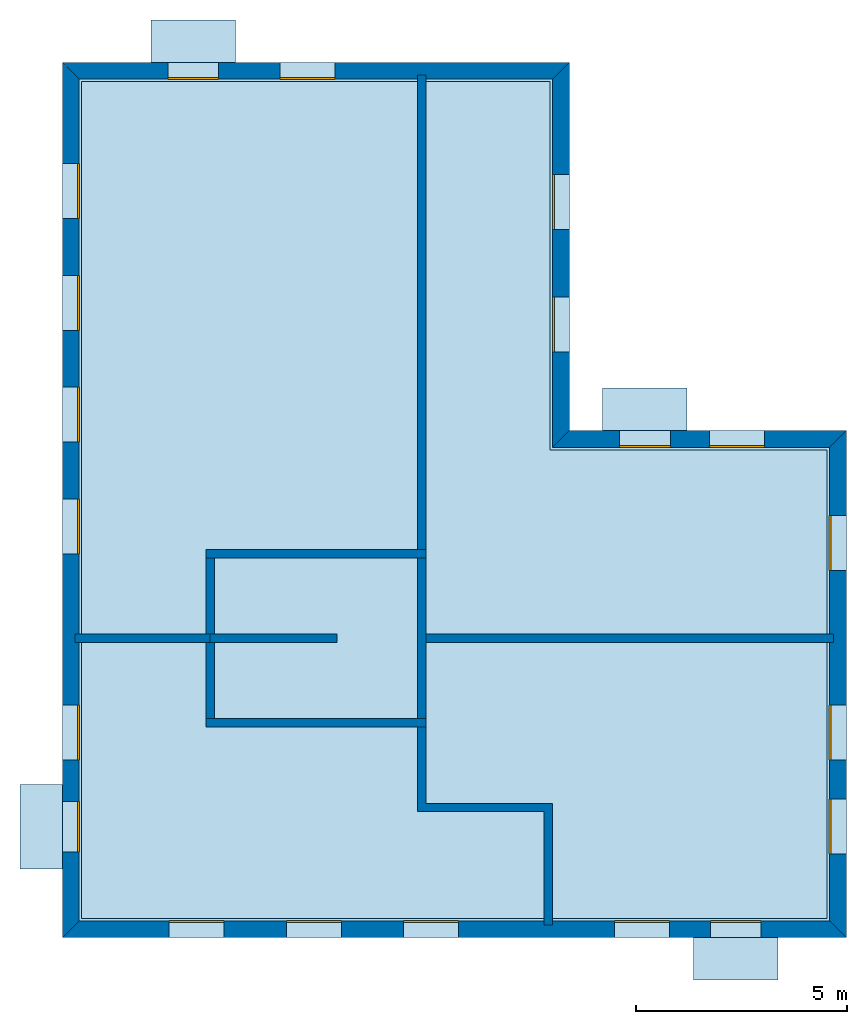
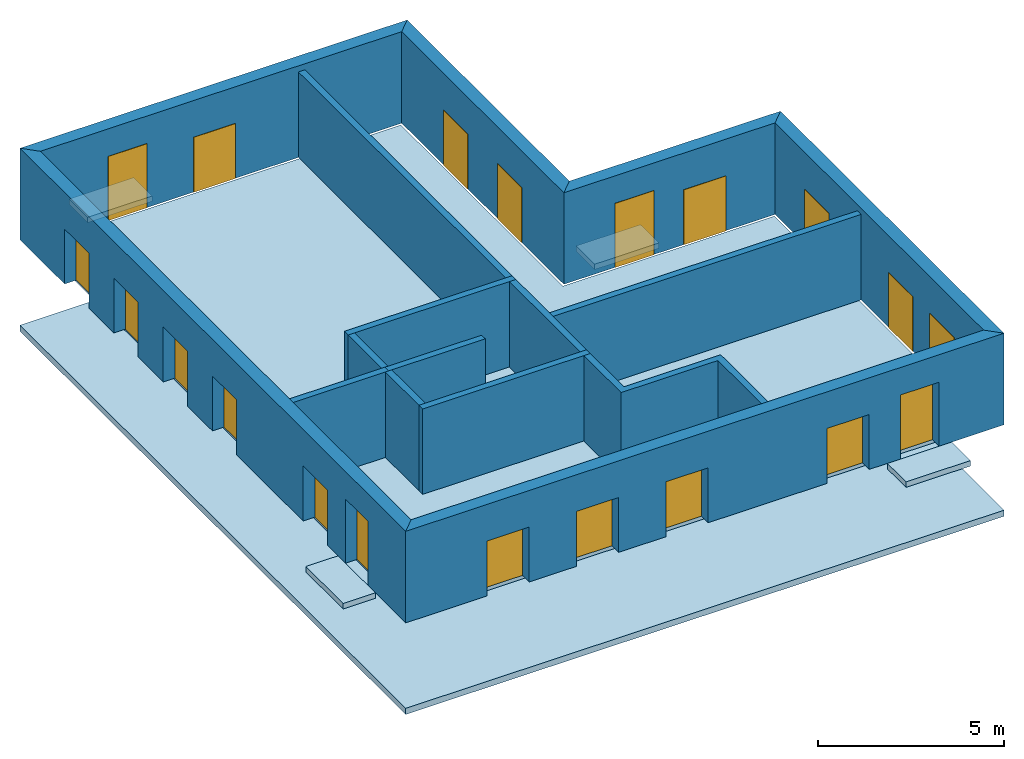
# One storey: 20 windows, 15 walls, 6 slabs, 20 openings.
"""IFC4 building model written with IfcOpenShell, lengths in metres."""

from ifc_helpers import new_model, si_unit, frame, origin_with_axes, place, context, subcontext, project, spatial, polyline, line, indexed_curve, outline, extrude, element, fill, save


model = new_model("IFC4")

# Units and contexts
model_context = context("Model", 3, precision=1e-05, world=origin_with_axes())
body_context = subcontext(model_context, "Body", "Model", "MODEL_VIEW")
ifc_project = project(units=[si_unit("AREAUNIT", "SQUARE_METRE"), si_unit("VOLUMEUNIT", "CUBIC_METRE"), si_unit("LENGTHUNIT", "METRE")], contexts=[model_context])

# Site, building, storey
site = spatial("IfcSite", under=ifc_project)
building = spatial("IfcBuilding", under=site, Name="Building 2")
storey_placement = place(None, frame((0.0, 0.0, 7.0), z_axis=(0.0, 0.0, 1.0), x_axis=(1.0, 0.0, 0.0)))
storey = spatial("IfcBuildingStorey", under=building, at=storey_placement, Name="03 Storey")

# Slabs
slab_1_placement = place(storey_placement, origin_with_axes())
element("IfcSlab", 1, at=slab_1_placement, inside=storey, Name="Slab", context=body_context, shape_type="SweptSolid", body=[
    extrude(outline(indexed_curve([(22.079464, -3.619175), (15.533354, -3.619175), (15.533354, 5.0882), (4.453354, 5.0882), (4.453354, -14.699175), (22.079464, -14.699175)], segments=[line(1, 2), line(2, 3), line(3, 4), line(4, 5), line(5, 6)])), origin_with_axes(), (0.0, 0.0, -1.0), 0.2),
])
slab_2_placement = place(storey_placement, origin_with_axes())
element("IfcSlab", 2, at=slab_2_placement, inside=storey, Name="Balcony", context=body_context, shape_type="SweptSolid", body=[
    extrude(outline(indexed_curve([(6.093354, 5.5482), (6.093354, 6.5482), (8.093354, 6.5482), (8.093354, 5.5482)], segments=[line(1, 2), line(2, 3), line(3, 4)])), origin_with_axes(), (0.0, 0.0, -1.0), 0.18),
])
slab_3_placement = place(storey_placement, origin_with_axes())
element("IfcSlab", 3, at=slab_3_placement, inside=storey, Name="Balcony", context=body_context, shape_type="SweptSolid", body=[
    extrude(outline(indexed_curve([(16.7753906666667, -3.159175), (16.7753906666667, -2.159175), (18.7753906666667, -2.159175), (18.7753906666667, -3.159175)], segments=[line(1, 2), line(2, 3), line(3, 4)])), origin_with_axes(), (0.0, 0.0, -1.0), 0.18),
])
slab_4_placement = place(storey_placement, origin_with_axes())
element("IfcSlab", 4, at=slab_4_placement, inside=storey, Name="Balcony", context=body_context, shape_type="SweptSolid", body=[
    extrude(outline(indexed_curve([(20.924094, -15.159175), (20.924094, -16.159175), (18.924094, -16.159175), (18.924094, -15.159175)], segments=[line(1, 2), line(2, 3), line(3, 4)])), origin_with_axes(), (0.0, 0.0, -1.0), 0.18),
])
slab_5_placement = place(storey_placement, origin_with_axes())
element("IfcSlab", 5, at=slab_5_placement, inside=storey, Name="Balcony", context=body_context, shape_type="SweptSolid", body=[
    extrude(outline(indexed_curve([(3.993354, -13.5322976666667), (2.993354, -13.5322976666667), (2.993354, -11.5322976666667), (3.993354, -11.5322976666667)], segments=[line(1, 2), line(2, 3), line(3, 4)])), origin_with_axes(), (0.0, 0.0, -1.0), 0.18),
])
slab_6_placement = place(storey_placement, frame((22.5394649505615, -3.15917491912842, 0.0), z_axis=(-1.07062027704125e-23, 1.22464679914735e-16, -1.0), x_axis=(-0.999999999999996, -8.74227800037247e-08, 0.0)))
element("IfcSlab", 6, at=slab_6_placement, inside=storey, Name="Slab", context=body_context, shape_type="SweptSolid", body=[
    extrude(outline(polyline([(0.0, 0.0), (6.54611, 0.0), (6.54611, 8.707375), (18.54611, 8.707375), (18.54611, -12.0), (0.0, -12.0), (0.0, 0.0)])), frame((0.0, 0.0, 3.0), z_axis=(0.0, 0.0, 1.0), x_axis=(1.0, 0.0, 0.0)), (0.0, -4.37113882867379e-08, -1.0), 0.2),
])

# Walls
wall_1_placement = place(storey_placement, origin_with_axes())
element("IfcWall", 7, at=wall_1_placement, inside=storey, Name="Wall", context=body_context, shape_type="SweptSolid", body=[
    extrude(outline(indexed_curve([(7.593354, -7.978543), (4.293354, -7.978543), (4.293354, -8.178543), (7.593354, -8.178543)], segments=[line(1, 2), line(2, 3), line(3, 4)])), origin_with_axes(), (0.0, 0.0, 1.0), 2.8),
])
wall_2_placement = place(storey_placement, origin_with_axes())
element("IfcWall", 8, at=wall_2_placement, inside=storey, Name="Wall", context=body_context, shape_type="SweptSolid", body=[
    extrude(outline(indexed_curve([(12.593354, 5.2482), (12.393354, 5.2482), (12.393354, -6.178543), (12.593354, -6.178543)], segments=[line(1, 2), line(2, 3), line(3, 4)])), origin_with_axes(), (0.0, 0.0, 1.0), 2.8),
])
wall_3_placement = place(storey_placement, origin_with_axes())
element("IfcWall", 9, at=wall_3_placement, inside=storey, Name="Wall", context=body_context, shape_type="SweptSolid", body=[
    extrude(outline(indexed_curve([(22.239464, -7.978543), (12.393354, -7.978543), (12.393354, -8.178543), (22.239464, -8.178543)], segments=[line(1, 2), line(2, 3), line(3, 4)])), origin_with_axes(), (0.0, 0.0, 1.0), 2.8),
])
wall_4_placement = place(storey_placement, origin_with_axes())
element("IfcWall", 10, at=wall_4_placement, inside=storey, Name="Wall", context=body_context, shape_type="SweptSolid", body=[
    extrude(outline(indexed_curve([(15.593354, -11.978543), (12.593354, -11.978543), (12.593354, -9.978543), (12.393354, -9.978543), (12.393354, -12.178543), (15.393354, -12.178543), (15.393354, -14.859175), (15.593354, -14.859175)], segments=[line(1, 2), line(2, 3), line(3, 4), line(4, 5), line(5, 6), line(6, 7), line(7, 8)])), origin_with_axes(), (0.0, 0.0, 1.0), 2.8),
])

# Wall, openings, windows
wall_5_placement = place(storey_placement, origin_with_axes())
wall_5 = element("IfcWall", 11, at=wall_5_placement, inside=storey, Name="Facade", context=body_context, shape_type="SweptSolid", body=[
    extrude(outline(indexed_curve([(22.139464, -3.559175), (15.593354, -3.559175), (15.993354, -3.159175), (22.539464, -3.159175)], segments=[line(1, 2), line(2, 3), line(3, 4)])), origin_with_axes(), (0.0, 0.0, 1.0), 3.0),
])
opening_1_placement = place(wall_5_placement, origin_with_axes())
opening_1 = element("IfcOpeningElement", 12, at=opening_1_placement, cuts=wall_5, Name="Opening", context=body_context, shape_type="SweptSolid", body=[
    extrude(outline(indexed_curve([(20.6074273333333, -3.119175), (20.6074273333333, -3.619175), (19.3074273333333, -3.619175), (19.3074273333333, -3.119175)], segments=[line(1, 2), line(2, 3), line(3, 4)])), origin_with_axes(), (0.0, 0.0, 1.0), 1.8),
])
opening_2_placement = place(wall_5_placement, origin_with_axes())
opening_2 = element("IfcOpeningElement", 13, at=opening_2_placement, cuts=wall_5, Name="Opening", context=body_context, shape_type="SweptSolid", body=[
    extrude(outline(indexed_curve([(18.3753906666667, -3.119175), (18.3753906666667, -3.619175), (17.1753906666667, -3.619175), (17.1753906666667, -3.119175)], segments=[line(1, 2), line(2, 3), line(3, 4)])), origin_with_axes(), (0.0, 0.0, 1.0), 2.1),
])
window_1_placement = place(storey_placement, origin_with_axes())
window_1 = element("IfcWindow", 14, at=window_1_placement, inside=storey, Name="Window", PredefinedType="WINDOW", context=body_context, shape_type="SweptSolid", body=[
    extrude(outline(indexed_curve([(20.6074273333333, -3.519175), (20.6074273333333, -3.569175), (19.3074273333333, -3.569175), (19.3074273333333, -3.519175)], segments=[line(1, 2), line(2, 3), line(3, 4)])), origin_with_axes(), (0.0, 0.0, 1.0), 1.8),
])
fill(opening_1, window_1)
window_2_placement = place(storey_placement, origin_with_axes())
window_2 = element("IfcWindow", 15, at=window_2_placement, inside=storey, Name="Window", PredefinedType="WINDOW", context=body_context, shape_type="SweptSolid", body=[
    extrude(outline(indexed_curve([(18.3753906666667, -3.519175), (18.3753906666667, -3.569175), (17.1753906666667, -3.569175), (17.1753906666667, -3.519175)], segments=[line(1, 2), line(2, 3), line(3, 4)])), origin_with_axes(), (0.0, 0.0, 1.0), 2.1),
])
fill(opening_2, window_2)

wall_6_placement = place(storey_placement, origin_with_axes())
wall_6 = element("IfcWall", 16, at=wall_6_placement, inside=storey, Name="Facade", context=body_context, shape_type="SweptSolid", body=[
    extrude(outline(indexed_curve([(15.593354, -3.559175), (15.593354, 5.1482), (15.993354, 5.5482), (15.993354, -3.159175)], segments=[line(1, 2), line(2, 3), line(3, 4)])), origin_with_axes(), (0.0, 0.0, 1.0), 3.0),
])
opening_3_placement = place(wall_6_placement, origin_with_axes())
opening_3 = element("IfcOpeningElement", 17, at=opening_3_placement, cuts=wall_6, Name="Opening", context=body_context, shape_type="SweptSolid", body=[
    extrude(outline(indexed_curve([(16.033354, -1.30671666666667), (15.533354, -1.30671666666667), (15.533354, -0.00671666666666659), (16.033354, -0.00671666666666659)], segments=[line(1, 2), line(2, 3), line(3, 4)])), origin_with_axes(), (0.0, 0.0, 1.0), 1.8),
])
opening_4_placement = place(wall_6_placement, origin_with_axes())
opening_4 = element("IfcOpeningElement", 18, at=opening_4_placement, cuts=wall_6, Name="Opening", context=body_context, shape_type="SweptSolid", body=[
    extrude(outline(indexed_curve([(16.033354, 1.59574166666667), (15.533354, 1.59574166666667), (15.533354, 2.89574166666667), (16.033354, 2.89574166666667)], segments=[line(1, 2), line(2, 3), line(3, 4)])), origin_with_axes(), (0.0, 0.0, 1.0), 1.8),
])
window_3_placement = place(storey_placement, origin_with_axes())
window_3 = element("IfcWindow", 19, at=window_3_placement, inside=storey, Name="Window", PredefinedType="WINDOW", context=body_context, shape_type="SweptSolid", body=[
    extrude(outline(indexed_curve([(15.633354, -1.30671666666667), (15.583354, -1.30671666666667), (15.583354, -0.00671666666666659), (15.633354, -0.00671666666666659)], segments=[line(1, 2), line(2, 3), line(3, 4)])), origin_with_axes(), (0.0, 0.0, 1.0), 1.8),
])
fill(opening_3, window_3)
window_4_placement = place(storey_placement, origin_with_axes())
window_4 = element("IfcWindow", 20, at=window_4_placement, inside=storey, Name="Window", PredefinedType="WINDOW", context=body_context, shape_type="SweptSolid", body=[
    extrude(outline(indexed_curve([(15.633354, 1.59574166666667), (15.583354, 1.59574166666667), (15.583354, 2.89574166666667), (15.633354, 2.89574166666667)], segments=[line(1, 2), line(2, 3), line(3, 4)])), origin_with_axes(), (0.0, 0.0, 1.0), 1.8),
])
fill(opening_4, window_4)

wall_7_placement = place(storey_placement, origin_with_axes())
wall_7 = element("IfcWall", 21, at=wall_7_placement, inside=storey, Name="Facade", context=body_context, shape_type="SweptSolid", body=[
    extrude(outline(indexed_curve([(15.593354, 5.1482), (4.393354, 5.1482), (3.993354, 5.5482), (15.993354, 5.5482)], segments=[line(1, 2), line(2, 3), line(3, 4)])), origin_with_axes(), (0.0, 0.0, 1.0), 3.0),
])
opening_5_placement = place(wall_7_placement, origin_with_axes())
opening_5 = element("IfcOpeningElement", 22, at=opening_5_placement, cuts=wall_7, Name="Opening", context=body_context, shape_type="SweptSolid", body=[
    extrude(outline(indexed_curve([(10.443354, 5.5882), (10.443354, 5.0882), (9.143354, 5.0882), (9.143354, 5.5882)], segments=[line(1, 2), line(2, 3), line(3, 4)])), origin_with_axes(), (0.0, 0.0, 1.0), 1.8),
])
opening_6_placement = place(wall_7_placement, origin_with_axes())
opening_6 = element("IfcOpeningElement", 23, at=opening_6_placement, cuts=wall_7, Name="Opening", context=body_context, shape_type="SweptSolid", body=[
    extrude(outline(indexed_curve([(7.693354, 5.5882), (7.693354, 5.0882), (6.493354, 5.0882), (6.493354, 5.5882)], segments=[line(1, 2), line(2, 3), line(3, 4)])), origin_with_axes(), (0.0, 0.0, 1.0), 2.1),
])
window_5_placement = place(storey_placement, origin_with_axes())
window_5 = element("IfcWindow", 24, at=window_5_placement, inside=storey, Name="Window", PredefinedType="WINDOW", context=body_context, shape_type="SweptSolid", body=[
    extrude(outline(indexed_curve([(10.443354, 5.1882), (10.443354, 5.1382), (9.143354, 5.1382), (9.143354, 5.1882)], segments=[line(1, 2), line(2, 3), line(3, 4)])), origin_with_axes(), (0.0, 0.0, 1.0), 1.8),
])
fill(opening_5, window_5)
window_6_placement = place(storey_placement, origin_with_axes())
window_6 = element("IfcWindow", 25, at=window_6_placement, inside=storey, Name="Window", PredefinedType="WINDOW", context=body_context, shape_type="SweptSolid", body=[
    extrude(outline(indexed_curve([(7.693354, 5.1882), (7.693354, 5.1382), (6.493354, 5.1382), (6.493354, 5.1882)], segments=[line(1, 2), line(2, 3), line(3, 4)])), origin_with_axes(), (0.0, 0.0, 1.0), 2.1),
])
fill(opening_6, window_6)

wall_8_placement = place(storey_placement, origin_with_axes())
wall_8 = element("IfcWall", 26, at=wall_8_placement, inside=storey, Name="Facade", context=body_context, shape_type="SweptSolid", body=[
    extrude(outline(indexed_curve([(4.393354, 5.1482), (4.393354, -14.759175), (3.993354, -15.159175), (3.993354, 5.5482)], segments=[line(1, 2), line(2, 3), line(3, 4)])), origin_with_axes(), (0.0, 0.0, 1.0), 3.0),
])
opening_7_placement = place(wall_8_placement, origin_with_axes())
opening_7 = element("IfcOpeningElement", 27, at=opening_7_placement, cuts=wall_8, Name="Opening", context=body_context, shape_type="SweptSolid", body=[
    extrude(outline(indexed_curve([(3.953354, 3.1528514), (4.453354, 3.1528514), (4.453354, 1.8528514), (3.953354, 1.8528514)], segments=[line(1, 2), line(2, 3), line(3, 4)])), origin_with_axes(), (0.0, 0.0, 1.0), 1.8),
])
opening_8_placement = place(wall_8_placement, origin_with_axes())
opening_8 = element("IfcOpeningElement", 28, at=opening_8_placement, cuts=wall_8, Name="Opening", context=body_context, shape_type="SweptSolid", body=[
    extrude(outline(indexed_curve([(3.953354, 0.507502800000001), (4.453354, 0.507502800000001), (4.453354, -0.792497199999999), (3.953354, -0.792497199999999)], segments=[line(1, 2), line(2, 3), line(3, 4)])), origin_with_axes(), (0.0, 0.0, 1.0), 1.8),
])
opening_9_placement = place(wall_8_placement, origin_with_axes())
opening_9 = element("IfcOpeningElement", 29, at=opening_9_placement, cuts=wall_8, Name="Opening", context=body_context, shape_type="SweptSolid", body=[
    extrude(outline(indexed_curve([(3.953354, -2.1378458), (4.453354, -2.1378458), (4.453354, -3.4378458), (3.953354, -3.4378458)], segments=[line(1, 2), line(2, 3), line(3, 4)])), origin_with_axes(), (0.0, 0.0, 1.0), 1.8),
])
opening_10_placement = place(wall_8_placement, origin_with_axes())
opening_10 = element("IfcOpeningElement", 30, at=opening_10_placement, cuts=wall_8, Name="Opening", context=body_context, shape_type="SweptSolid", body=[
    extrude(outline(indexed_curve([(3.953354, -4.7831944), (4.453354, -4.7831944), (4.453354, -6.0831944), (3.953354, -6.0831944)], segments=[line(1, 2), line(2, 3), line(3, 4)])), origin_with_axes(), (0.0, 0.0, 1.0), 1.8),
])
opening_11_placement = place(wall_8_placement, origin_with_axes())
opening_11 = element("IfcOpeningElement", 31, at=opening_11_placement, cuts=wall_8, Name="Opening", context=body_context, shape_type="SweptSolid", body=[
    extrude(outline(indexed_curve([(3.953354, -9.65542033333333), (4.453354, -9.65542033333333), (4.453354, -10.9554203333333), (3.953354, -10.9554203333333)], segments=[line(1, 2), line(2, 3), line(3, 4)])), origin_with_axes(), (0.0, 0.0, 1.0), 1.8),
])
opening_12_placement = place(wall_8_placement, origin_with_axes())
opening_12 = element("IfcOpeningElement", 32, at=opening_12_placement, cuts=wall_8, Name="Opening", context=body_context, shape_type="SweptSolid", body=[
    extrude(outline(indexed_curve([(3.953354, -11.9322976666667), (4.453354, -11.9322976666667), (4.453354, -13.1322976666667), (3.953354, -13.1322976666667)], segments=[line(1, 2), line(2, 3), line(3, 4)])), origin_with_axes(), (0.0, 0.0, 1.0), 2.1),
])
window_7_placement = place(storey_placement, origin_with_axes())
window_7 = element("IfcWindow", 33, at=window_7_placement, inside=storey, Name="Window", PredefinedType="WINDOW", context=body_context, shape_type="SweptSolid", body=[
    extrude(outline(indexed_curve([(4.353354, 3.1528514), (4.403354, 3.1528514), (4.403354, 1.8528514), (4.353354, 1.8528514)], segments=[line(1, 2), line(2, 3), line(3, 4)])), origin_with_axes(), (0.0, 0.0, 1.0), 1.8),
])
fill(opening_7, window_7)
window_8_placement = place(storey_placement, origin_with_axes())
window_8 = element("IfcWindow", 34, at=window_8_placement, inside=storey, Name="Window", PredefinedType="WINDOW", context=body_context, shape_type="SweptSolid", body=[
    extrude(outline(indexed_curve([(4.353354, 0.507502800000001), (4.403354, 0.507502800000001), (4.403354, -0.792497199999999), (4.353354, -0.792497199999999)], segments=[line(1, 2), line(2, 3), line(3, 4)])), origin_with_axes(), (0.0, 0.0, 1.0), 1.8),
])
fill(opening_8, window_8)
window_9_placement = place(storey_placement, origin_with_axes())
window_9 = element("IfcWindow", 35, at=window_9_placement, inside=storey, Name="Window", PredefinedType="WINDOW", context=body_context, shape_type="SweptSolid", body=[
    extrude(outline(indexed_curve([(4.353354, -2.1378458), (4.403354, -2.1378458), (4.403354, -3.4378458), (4.353354, -3.4378458)], segments=[line(1, 2), line(2, 3), line(3, 4)])), origin_with_axes(), (0.0, 0.0, 1.0), 1.8),
])
fill(opening_9, window_9)
window_10_placement = place(storey_placement, origin_with_axes())
window_10 = element("IfcWindow", 36, at=window_10_placement, inside=storey, Name="Window", PredefinedType="WINDOW", context=body_context, shape_type="SweptSolid", body=[
    extrude(outline(indexed_curve([(4.353354, -4.7831944), (4.403354, -4.7831944), (4.403354, -6.0831944), (4.353354, -6.0831944)], segments=[line(1, 2), line(2, 3), line(3, 4)])), origin_with_axes(), (0.0, 0.0, 1.0), 1.8),
])
fill(opening_10, window_10)
window_11_placement = place(storey_placement, origin_with_axes())
window_11 = element("IfcWindow", 37, at=window_11_placement, inside=storey, Name="Window", PredefinedType="WINDOW", context=body_context, shape_type="SweptSolid", body=[
    extrude(outline(indexed_curve([(4.353354, -9.65542033333333), (4.403354, -9.65542033333333), (4.403354, -10.9554203333333), (4.353354, -10.9554203333333)], segments=[line(1, 2), line(2, 3), line(3, 4)])), origin_with_axes(), (0.0, 0.0, 1.0), 1.8),
])
fill(opening_11, window_11)
window_12_placement = place(storey_placement, origin_with_axes())
window_12 = element("IfcWindow", 38, at=window_12_placement, inside=storey, Name="Window", PredefinedType="WINDOW", context=body_context, shape_type="SweptSolid", body=[
    extrude(outline(indexed_curve([(4.353354, -11.9322976666667), (4.403354, -11.9322976666667), (4.403354, -13.1322976666667), (4.353354, -13.1322976666667)], segments=[line(1, 2), line(2, 3), line(3, 4)])), origin_with_axes(), (0.0, 0.0, 1.0), 2.1),
])
fill(opening_12, window_12)

wall_9_placement = place(storey_placement, origin_with_axes())
wall_9 = element("IfcWall", 39, at=wall_9_placement, inside=storey, Name="Facade", context=body_context, shape_type="SweptSolid", body=[
    extrude(outline(indexed_curve([(4.393354, -14.759175), (22.139464, -14.759175), (22.539464, -15.159175), (3.993354, -15.159175)], segments=[line(1, 2), line(2, 3), line(3, 4)])), origin_with_axes(), (0.0, 0.0, 1.0), 3.0),
])
opening_13_placement = place(wall_9_placement, origin_with_axes())
opening_13 = element("IfcOpeningElement", 40, at=opening_13_placement, cuts=wall_9, Name="Opening", context=body_context, shape_type="SweptSolid", body=[
    extrude(outline(indexed_curve([(17.058724, -15.199175), (17.058724, -14.699175), (18.358724, -14.699175), (18.358724, -15.199175)], segments=[line(1, 2), line(2, 3), line(3, 4)])), origin_with_axes(), (0.0, 0.0, 1.0), 1.8),
])
opening_14_placement = place(wall_9_placement, origin_with_axes())
opening_14 = element("IfcOpeningElement", 41, at=opening_14_placement, cuts=wall_9, Name="Opening", context=body_context, shape_type="SweptSolid", body=[
    extrude(outline(indexed_curve([(19.324094, -15.199175), (19.324094, -14.699175), (20.524094, -14.699175), (20.524094, -15.199175)], segments=[line(1, 2), line(2, 3), line(3, 4)])), origin_with_axes(), (0.0, 0.0, 1.0), 2.1),
])
opening_15_placement = place(wall_9_placement, origin_with_axes())
opening_15 = element("IfcOpeningElement", 42, at=opening_15_placement, cuts=wall_9, Name="Opening", context=body_context, shape_type="SweptSolid", body=[
    extrude(outline(indexed_curve([(6.518354, -15.199175), (6.518354, -14.699175), (7.818354, -14.699175), (7.818354, -15.199175)], segments=[line(1, 2), line(2, 3), line(3, 4)])), origin_with_axes(), (0.0, 0.0, 1.0), 1.8),
])
opening_16_placement = place(wall_9_placement, origin_with_axes())
opening_16 = element("IfcOpeningElement", 43, at=opening_16_placement, cuts=wall_9, Name="Opening", context=body_context, shape_type="SweptSolid", body=[
    extrude(outline(indexed_curve([(9.293354, -15.199175), (9.293354, -14.699175), (10.593354, -14.699175), (10.593354, -15.199175)], segments=[line(1, 2), line(2, 3), line(3, 4)])), origin_with_axes(), (0.0, 0.0, 1.0), 1.8),
])
opening_17_placement = place(wall_9_placement, origin_with_axes())
opening_17 = element("IfcOpeningElement", 44, at=opening_17_placement, cuts=wall_9, Name="Opening", context=body_context, shape_type="SweptSolid", body=[
    extrude(outline(indexed_curve([(12.068354, -15.199175), (12.068354, -14.699175), (13.368354, -14.699175), (13.368354, -15.199175)], segments=[line(1, 2), line(2, 3), line(3, 4)])), origin_with_axes(), (0.0, 0.0, 1.0), 1.8),
])
window_13_placement = place(storey_placement, origin_with_axes())
window_13 = element("IfcWindow", 45, at=window_13_placement, inside=storey, Name="Window", PredefinedType="WINDOW", context=body_context, shape_type="SweptSolid", body=[
    extrude(outline(indexed_curve([(17.058724, -14.799175), (17.058724, -14.749175), (18.358724, -14.749175), (18.358724, -14.799175)], segments=[line(1, 2), line(2, 3), line(3, 4)])), origin_with_axes(), (0.0, 0.0, 1.0), 1.8),
])
fill(opening_13, window_13)
window_14_placement = place(storey_placement, origin_with_axes())
window_14 = element("IfcWindow", 46, at=window_14_placement, inside=storey, Name="Window", PredefinedType="WINDOW", context=body_context, shape_type="SweptSolid", body=[
    extrude(outline(indexed_curve([(19.324094, -14.799175), (19.324094, -14.749175), (20.524094, -14.749175), (20.524094, -14.799175)], segments=[line(1, 2), line(2, 3), line(3, 4)])), origin_with_axes(), (0.0, 0.0, 1.0), 2.1),
])
fill(opening_14, window_14)
window_15_placement = place(storey_placement, origin_with_axes())
window_15 = element("IfcWindow", 47, at=window_15_placement, inside=storey, Name="Window", PredefinedType="WINDOW", context=body_context, shape_type="SweptSolid", body=[
    extrude(outline(indexed_curve([(6.518354, -14.799175), (6.518354, -14.749175), (7.818354, -14.749175), (7.818354, -14.799175)], segments=[line(1, 2), line(2, 3), line(3, 4)])), origin_with_axes(), (0.0, 0.0, 1.0), 1.8),
])
fill(opening_15, window_15)
window_16_placement = place(storey_placement, origin_with_axes())
window_16 = element("IfcWindow", 48, at=window_16_placement, inside=storey, Name="Window", PredefinedType="WINDOW", context=body_context, shape_type="SweptSolid", body=[
    extrude(outline(indexed_curve([(9.293354, -14.799175), (9.293354, -14.749175), (10.593354, -14.749175), (10.593354, -14.799175)], segments=[line(1, 2), line(2, 3), line(3, 4)])), origin_with_axes(), (0.0, 0.0, 1.0), 1.8),
])
fill(opening_16, window_16)
window_17_placement = place(storey_placement, origin_with_axes())
window_17 = element("IfcWindow", 49, at=window_17_placement, inside=storey, Name="Window", PredefinedType="WINDOW", context=body_context, shape_type="SweptSolid", body=[
    extrude(outline(indexed_curve([(12.068354, -14.799175), (12.068354, -14.749175), (13.368354, -14.749175), (13.368354, -14.799175)], segments=[line(1, 2), line(2, 3), line(3, 4)])), origin_with_axes(), (0.0, 0.0, 1.0), 1.8),
])
fill(opening_17, window_17)

wall_10_placement = place(storey_placement, origin_with_axes())
wall_10 = element("IfcWall", 50, at=wall_10_placement, inside=storey, Name="Facade", context=body_context, shape_type="SweptSolid", body=[
    extrude(outline(indexed_curve([(22.139464, -14.759175), (22.139464, -3.559175), (22.539464, -3.159175), (22.539464, -15.159175)], segments=[line(1, 2), line(2, 3), line(3, 4)])), origin_with_axes(), (0.0, 0.0, 1.0), 3.0),
])
opening_18_placement = place(wall_10_placement, origin_with_axes())
opening_18 = element("IfcOpeningElement", 51, at=opening_18_placement, cuts=wall_10, Name="Opening", context=body_context, shape_type="SweptSolid", body=[
    extrude(outline(indexed_curve([(22.579464, -6.468859), (22.079464, -6.468859), (22.079464, -5.168859), (22.579464, -5.168859)], segments=[line(1, 2), line(2, 3), line(3, 4)])), origin_with_axes(), (0.0, 0.0, 1.0), 1.8),
])
opening_19_placement = place(wall_10_placement, origin_with_axes())
opening_19 = element("IfcOpeningElement", 52, at=opening_19_placement, cuts=wall_10, Name="Opening", context=body_context, shape_type="SweptSolid", body=[
    extrude(outline(indexed_curve([(22.579464, -13.1822976666667), (22.079464, -13.1822976666667), (22.079464, -11.8822976666667), (22.579464, -11.8822976666667)], segments=[line(1, 2), line(2, 3), line(3, 4)])), origin_with_axes(), (0.0, 0.0, 1.0), 1.8),
])
opening_20_placement = place(wall_10_placement, origin_with_axes())
opening_20 = element("IfcOpeningElement", 53, at=opening_20_placement, cuts=wall_10, Name="Opening", context=body_context, shape_type="SweptSolid", body=[
    extrude(outline(indexed_curve([(22.579464, -10.9554203333333), (22.079464, -10.9554203333333), (22.079464, -9.65542033333333), (22.579464, -9.65542033333333)], segments=[line(1, 2), line(2, 3), line(3, 4)])), origin_with_axes(), (0.0, 0.0, 1.0), 1.8),
])
window_18_placement = place(storey_placement, origin_with_axes())
window_18 = element("IfcWindow", 54, at=window_18_placement, inside=storey, Name="Window", PredefinedType="WINDOW", context=body_context, shape_type="SweptSolid", body=[
    extrude(outline(indexed_curve([(22.179464, -6.468859), (22.129464, -6.468859), (22.129464, -5.168859), (22.179464, -5.168859)], segments=[line(1, 2), line(2, 3), line(3, 4)])), origin_with_axes(), (0.0, 0.0, 1.0), 1.8),
])
fill(opening_18, window_18)
window_19_placement = place(storey_placement, origin_with_axes())
window_19 = element("IfcWindow", 55, at=window_19_placement, inside=storey, Name="Window", PredefinedType="WINDOW", context=body_context, shape_type="SweptSolid", body=[
    extrude(outline(indexed_curve([(22.179464, -13.1822976666667), (22.129464, -13.1822976666667), (22.129464, -11.8822976666667), (22.179464, -11.8822976666667)], segments=[line(1, 2), line(2, 3), line(3, 4)])), origin_with_axes(), (0.0, 0.0, 1.0), 1.8),
])
fill(opening_19, window_19)
window_20_placement = place(storey_placement, origin_with_axes())
window_20 = element("IfcWindow", 56, at=window_20_placement, inside=storey, Name="Window", PredefinedType="WINDOW", context=body_context, shape_type="SweptSolid", body=[
    extrude(outline(indexed_curve([(22.179464, -10.9554203333333), (22.129464, -10.9554203333333), (22.129464, -9.65542033333333), (22.179464, -9.65542033333333)], segments=[line(1, 2), line(2, 3), line(3, 4)])), origin_with_axes(), (0.0, 0.0, 1.0), 1.8),
])
fill(opening_20, window_20)

# Walls
wall_11_placement = place(storey_placement, origin_with_axes())
element("IfcWall", 57, at=wall_11_placement, inside=storey, Name="CoreWall", context=body_context, shape_type="SweptSolid", body=[
    extrude(outline(indexed_curve([(12.593354, -5.978543), (7.393354, -5.978543), (7.393354, -6.178543), (12.593354, -6.178543)], segments=[line(1, 2), line(2, 3), line(3, 4)])), origin_with_axes(), (0.0, 0.0, 1.0), 2.8),
])
wall_12_placement = place(storey_placement, origin_with_axes())
element("IfcWall", 58, at=wall_12_placement, inside=storey, Name="CoreWall", context=body_context, shape_type="SweptSolid", body=[
    extrude(outline(indexed_curve([(7.393354, -10.178543), (12.593354, -10.178543), (12.593354, -9.978543), (7.393354, -9.978543)], segments=[line(1, 2), line(2, 3), line(3, 4)])), origin_with_axes(), (0.0, 0.0, 1.0), 2.8),
])
wall_13_placement = place(storey_placement, origin_with_axes())
element("IfcWall", 59, at=wall_13_placement, inside=storey, Name="CoreWall", context=body_context, shape_type="SweptSolid", body=[
    extrude(outline(indexed_curve([(7.593354, -9.978543), (7.593354, -6.178543), (7.393354, -6.178543), (7.393354, -9.978543)], segments=[line(1, 2), line(2, 3), line(3, 4)])), origin_with_axes(), (0.0, 0.0, 1.0), 2.8),
])
wall_14_placement = place(storey_placement, origin_with_axes())
element("IfcWall", 60, at=wall_14_placement, inside=storey, Name="CoreWall", context=body_context, shape_type="SweptSolid", body=[
    extrude(outline(indexed_curve([(12.393354, -6.178543), (12.393354, -9.978543), (12.593354, -9.978543), (12.593354, -6.178543)], segments=[line(1, 2), line(2, 3), line(3, 4)])), origin_with_axes(), (0.0, 0.0, 1.0), 2.8),
])
wall_15_placement = place(storey_placement, origin_with_axes())
element("IfcWall", 61, at=wall_15_placement, inside=storey, Name="CoreWall", context=body_context, shape_type="SweptSolid", body=[
    extrude(outline(indexed_curve([(10.493354, -7.978543), (7.493354, -7.978543), (7.493354, -8.178543), (10.493354, -8.178543)], segments=[line(1, 2), line(2, 3), line(3, 4)])), origin_with_axes(), (0.0, 0.0, 1.0), 2.8),
])

save(model, "model.ifc")
